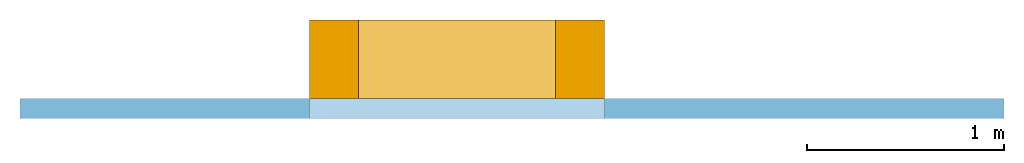
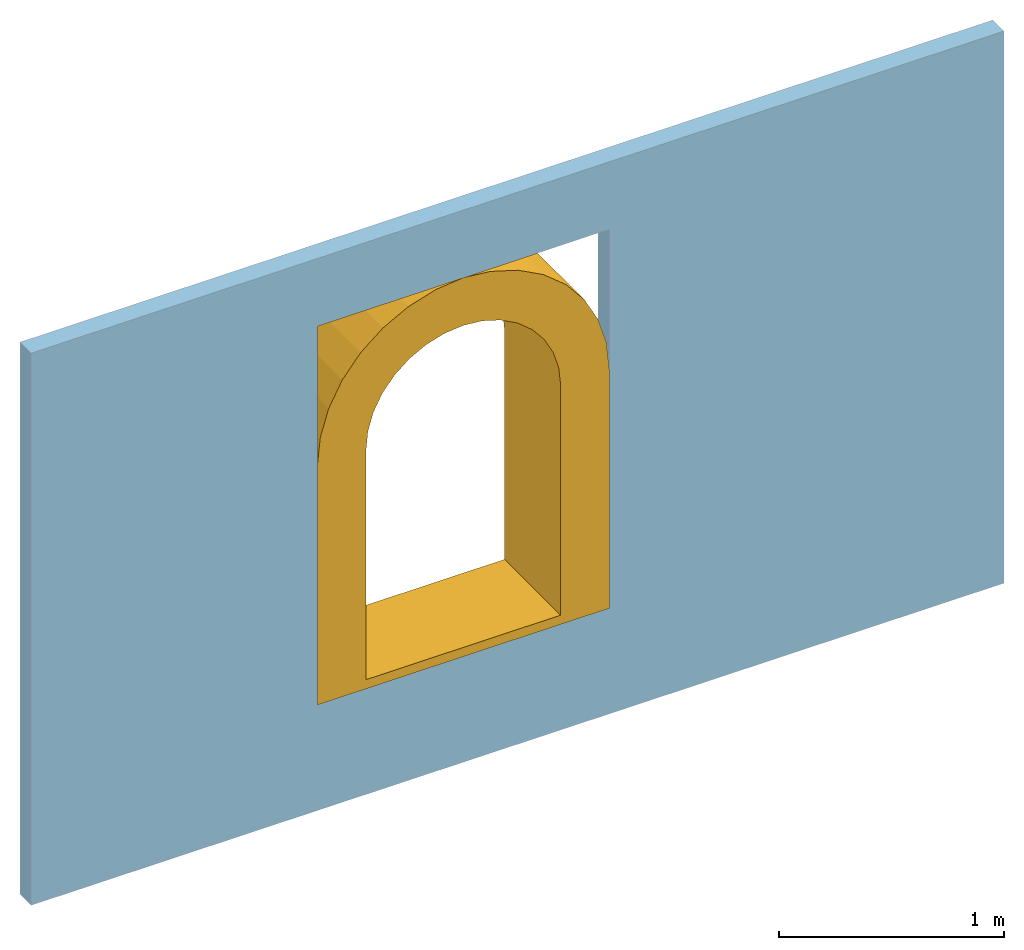
# One storey, part 2 of 2: 1 window, 1 opening, plus 1 element that does not belong to this part.
"""IFC4 building model written with IfcOpenShell, lengths in metres."""

from ifc_helpers import new_model, entity, si_unit, converted_unit, frame, origin_with_axes, origin_2d_with_axis, place, context, subcontext, project, spatial, line, indexed_curve, outline, extrude, polygons, source, transform, mapped, material, layer, layer_set, layer_usage, type_object, type_shapes, element, fill, save


model = new_model("IFC4")

# Units and contexts
model_context = context("Model", 3, precision=1e-05, world=origin_with_axes())
plan_context = context("Plan", 2, precision=1e-05, world=origin_2d_with_axis())
body_context = subcontext(model_context, "Body", "Model", "MODEL_VIEW")
ifc_project = project(units=[si_unit("AREAUNIT", "SQUARE_METRE"), si_unit("VOLUMEUNIT", "CUBIC_METRE"), si_unit("LENGTHUNIT", "METRE"), converted_unit("PLANEANGLEUNIT", "degree", entity("IfcReal", 0.0174532925199433), si_unit("PLANEANGLEUNIT", "RADIAN"), dimensions=[0, 0, 0, 0, 0, 0, 0])], contexts=[model_context, plan_context])

# Site, building, storey
site_placement = place(None, origin_with_axes())
site = spatial("IfcSite", under=ifc_project, at=site_placement)
building_placement = place(site_placement, origin_with_axes())
building = spatial("IfcBuilding", under=site, at=building_placement, Name="Building")
storey_placement = place(building_placement, origin_with_axes())
storey = spatial("IfcBuildingStorey", under=building, at=storey_placement, Name="Storey")

# Wall, opening, window
ifc_material = material()
ifc_layer = layer(ifc_material, 0.1)
ifc_layer_set = layer_set([ifc_layer])
ifc_layer_usage = layer_usage(ifc_layer_set, "AXIS2", "POSITIVE", 0.0)
wall_type = type_object("IfcWallType", Name="WAL100", PredefinedType="NOTDEFINED", material=ifc_layer_set)
wall_placement = place(storey_placement, frame((4.13492488861084, 0.0, 0.0), z_axis=(0.0, 0.0, 1.0), x_axis=(1.0, 0.0, 0.0)))
wall = element("IfcWall", 1, at=wall_placement, inside=storey, type_object=wall_type, material=ifc_layer_usage, Name="Wall", PredefinedType="NOTDEFINED", context=body_context, shape_type="SweptSolid", body=[
    extrude(outline(indexed_curve([(0.0, 0.0), (0.0, 0.1), (5.0, 0.1), (5.0, 0.0), (0.0, 0.0)], self_intersect=False)), origin_with_axes(), (0.0, 0.0, 1.0), 3.0),
])
shared_shape_1 = source(origin_with_axes(), body_context, "Body", "SweptSolid", [
    extrude(outline(indexed_curve([(0.0, 0.0, 0.0), (1.5, 0.0, 0.0), (1.5, 0.0, 2.05896019935608), (0.0, 0.0, 2.05896019935608)], segments=[line(1, 2), line(2, 3), line(3, 4), line(4, 1)])), frame((0.0, -0.100000001490116, 0.0), z_axis=(0.0, 0.0, 1.0), x_axis=(1.0, 0.0, 0.0)), (0.0, 1.0, 0.0), 0.300000001490116),
])
opening_placement = place(wall_placement, frame((1.47109985351562, 0.0, 0.574128270149231), z_axis=(0.0, 0.0, 1.0), x_axis=(1.0, 0.0, 0.0)))
opening = element("IfcOpeningElement", 2, at=opening_placement, cuts=wall, PredefinedType="OPENING", context=body_context, shape_type="MappedRepresentation", body=[
    mapped(shared_shape_1, transform((0.0, 0.0, 0.0), x_axis=(1.0, 0.0, 0.0), y_axis=(0.0, 1.0, 0.0), z_axis=(0.0, 0.0, 1.0), scale=1.0)),
])
window_type = type_object("IfcWindowType", Name="ArchedWindow", PartitioningType="NOTDEFINED", PredefinedType="NOTDEFINED")
shared_shape_2 = source(origin_with_axes(), body_context, "Body", "Tessellation", [
    polygons([(0.0, 0.0, 0.0), (0.0, 0.5, 0.0), (0.0, 0.5, 1.29999995231628), (0.25, 0.0, 0.0), (0.25, 0.0, 1.29999995231628), (0.25, 0.5, 0.0), (0.652454793453217, 3.72529065373328e-08, 1.79039263725281), (0.558658301830292, 2.9802325940409e-08, 1.76193976402283), (0.472214877605438, 5.9604651880818e-08, 1.7157347202301), (0.396446645259857, 5.9604651880818e-08, 1.65355324745178), (0.334265202283859, 2.9802325940409e-08, 1.5777850151062), (0.288060218095779, 2.9802325940409e-08, 1.49134159088135), (0.259607344865799, 2.9802325940409e-08, 1.39754509925842), (0.75, 4.09781968357947e-08, 1.79999995231628), (0.472214877605438, 0.500000059604645, 1.7157347202301), (0.558658301830292, 0.500000059604645, 1.76193976402283), (0.652454793453217, 0.500000059604645, 1.79039263725281), (0.75, 0.500000059604645, 1.79999995231628), (0.25, 0.5, 1.29999995231628), (0.259607344865799, 0.500000059604645, 1.39754509925842), (0.288060218095779, 0.500000059604645, 1.49134159088135), (0.334265202283859, 0.500000059604645, 1.5777850151062), (0.396446645259857, 0.500000059604645, 1.65355324745178), (0.610894322395325, 5.65469449043121e-08, 2.04437708854675), (0.468518733978271, 4.52375594761634e-08, 2.00118780136108), (0.337304502725601, 9.04751189523267e-08, 1.93105220794678), (0.222294330596924, 9.04751189523267e-08, 1.83666563034058), (0.127907872200012, 4.52375594761634e-08, 1.72165560722351), (0.0577723979949951, 4.52375594761634e-08, 1.59044134616852), (0.0145831704139709, 4.52375594761634e-08, 1.44806575775146), (0.0, 0.0, 1.29999995231628), (0.75, 6.2201642947457e-08, 2.05896019935608), (0.337304502725601, 0.50000011920929, 1.93105220794678), (0.468518733978271, 0.50000011920929, 2.00118780136108), (0.610894322395325, 0.50000011920929, 2.04437708854675), (0.75, 0.50000011920929, 2.05896019935608), (0.0145831704139709, 0.50000011920929, 1.44806575775146), (0.0577723979949951, 0.50000011920929, 1.59044134616852), (0.127907872200012, 0.50000011920929, 1.72165560722351), (0.222294330596924, 0.50000011920929, 1.83666563034058), (1.5, 0.0, 0.0), (1.5, 0.5, 0.0), (1.5, 0.5, 1.29999995231628), (1.25, 0.0, 0.0), (1.25, 0.0, 1.29999995231628), (1.25, 0.5, 0.0), (0.847545206546783, 3.72529065373328e-08, 1.79039263725281), (0.941341698169708, 2.9802325940409e-08, 1.76193976402283), (1.02778506278992, 5.9604651880818e-08, 1.7157347202301), (1.1035532951355, 5.9604651880818e-08, 1.65355324745178), (1.16573476791382, 2.9802325940409e-08, 1.5777850151062), (1.21193981170654, 2.9802325940409e-08, 1.49134159088135), (1.24039268493652, 2.9802325940409e-08, 1.39754509925842), (1.02778506278992, 0.500000059604645, 1.7157347202301), (0.941341698169708, 0.500000059604645, 1.76193976402283), (0.847545206546783, 0.500000059604645, 1.79039263725281), (1.25, 0.5, 1.29999995231628), (1.24039268493652, 0.500000059604645, 1.39754509925842), (1.21193981170654, 0.500000059604645, 1.49134159088135), (1.16573476791382, 0.500000059604645, 1.5777850151062), (1.1035532951355, 0.500000059604645, 1.65355324745178), (0.889105677604675, 5.65469449043121e-08, 2.04437708854675), (1.03148126602173, 4.52375594761634e-08, 2.00118780136108), (1.16269552707672, 9.04751189523267e-08, 1.93105220794678), (1.27770566940308, 9.04751189523267e-08, 1.83666563034058), (1.37209212779999, 4.52375594761634e-08, 1.72165560722351), (1.442227602005, 4.52375594761634e-08, 1.59044134616852), (1.48541688919067, 4.52375594761634e-08, 1.44806575775146), (1.5, 0.0, 1.29999995231628), (1.16269552707672, 0.50000011920929, 1.93105220794678), (1.03148126602173, 0.50000011920929, 2.00118780136108), (0.889105677604675, 0.50000011920929, 2.04437708854675), (1.48541688919067, 0.50000011920929, 1.44806575775146), (1.442227602005, 0.50000011920929, 1.59044134616852), (1.37209212779999, 0.50000011920929, 1.72165560722351), (1.27770566940308, 0.50000011920929, 1.83666563034058), (0.0, 0.5, 0.0500000715255737), (0.25, 0.0, 0.0500000715255737), (0.0, 0.0, 0.0500000715255737), (0.25, 0.5, 0.0500000715255737), (1.5, 0.5, 0.0499999523162842), (1.25, 0.0, 0.0499999523162842), (1.5, 0.0, 0.0499999523162842), (1.25, 0.5, 0.0499999523162842)], [[[79, 31, 3, 77]], [[77, 3, 19, 80]], [[80, 19, 5, 78]], [[78, 5, 31, 79]], [[2, 6, 4, 1]], [[5, 19, 20, 13]], [[13, 20, 21, 12]], [[21, 22, 11, 12]], [[22, 23, 10, 11]], [[23, 15, 9, 10]], [[9, 15, 16, 8]], [[16, 17, 7, 8]], [[7, 17, 18, 14]], [[31, 30, 37, 3]], [[30, 29, 38, 37]], [[38, 29, 28, 39]], [[39, 28, 27, 40]], [[40, 27, 26, 33]], [[26, 25, 34, 33]], [[34, 25, 24, 35]], [[24, 32, 36, 35]], [[31, 5, 13, 30]], [[12, 29, 30, 13]], [[11, 28, 29, 12]], [[10, 27, 28, 11]], [[26, 27, 10, 9]], [[25, 26, 9, 8]], [[24, 25, 8, 7]], [[32, 24, 7, 14]], [[20, 19, 3, 37]], [[38, 21, 20, 37]], [[38, 39, 22, 21]], [[22, 39, 40, 23]], [[23, 40, 33, 15]], [[15, 33, 34, 16]], [[16, 34, 35, 17]], [[17, 35, 36, 18]], [[83, 81, 43, 69]], [[81, 84, 57, 43]], [[84, 82, 45, 57]], [[82, 83, 69, 45]], [[42, 41, 44, 46]], [[45, 53, 58, 57]], [[53, 52, 59, 58]], [[59, 52, 51, 60]], [[60, 51, 50, 61]], [[61, 50, 49, 54]], [[49, 48, 55, 54]], [[55, 48, 47, 56]], [[47, 14, 18, 56]], [[69, 43, 73, 68]], [[68, 73, 74, 67]], [[74, 75, 66, 67]], [[75, 76, 65, 66]], [[76, 70, 64, 65]], [[64, 70, 71, 63]], [[71, 72, 62, 63]], [[62, 72, 36, 32]], [[69, 68, 53, 45]], [[52, 53, 68, 67]], [[51, 52, 67, 66]], [[50, 51, 66, 65]], [[64, 49, 50, 65]], [[63, 48, 49, 64]], [[62, 47, 48, 63]], [[32, 14, 47, 62]], [[58, 73, 43, 57]], [[74, 73, 58, 59]], [[74, 59, 60, 75]], [[60, 61, 76, 75]], [[61, 54, 70, 76]], [[54, 55, 71, 70]], [[55, 56, 72, 71]], [[56, 18, 36, 72]], [[4, 78, 79, 1]], [[4, 44, 82, 78]], [[2, 77, 80, 6]], [[1, 79, 77, 2]], [[44, 41, 83, 82]], [[80, 78, 82, 84]], [[42, 46, 84, 81]], [[41, 42, 81, 83]], [[6, 46, 44, 4]], [[6, 80, 84, 46]]]),
])
type_shapes(window_type, [shared_shape_2])
window_placement = place(storey_placement, frame((5.60602474212646, 0.0, 0.574128270149231), z_axis=(0.0, 0.0, 1.0), x_axis=(1.0, 0.0, 0.0)))
window = element("IfcWindow", 3, at=window_placement, inside=storey, type_object=window_type, Name="Window", PredefinedType="NOTDEFINED", context=body_context, shape_type="MappedRepresentation", body=[
    mapped(shared_shape_2, transform((0.0, 0.0, 0.0), x_axis=(1.0, 0.0, 0.0), y_axis=(0.0, 1.0, 0.0), z_axis=(0.0, 0.0, 1.0), scale=1.0)),
])
fill(opening, window)

save(model, "model.ifc")
